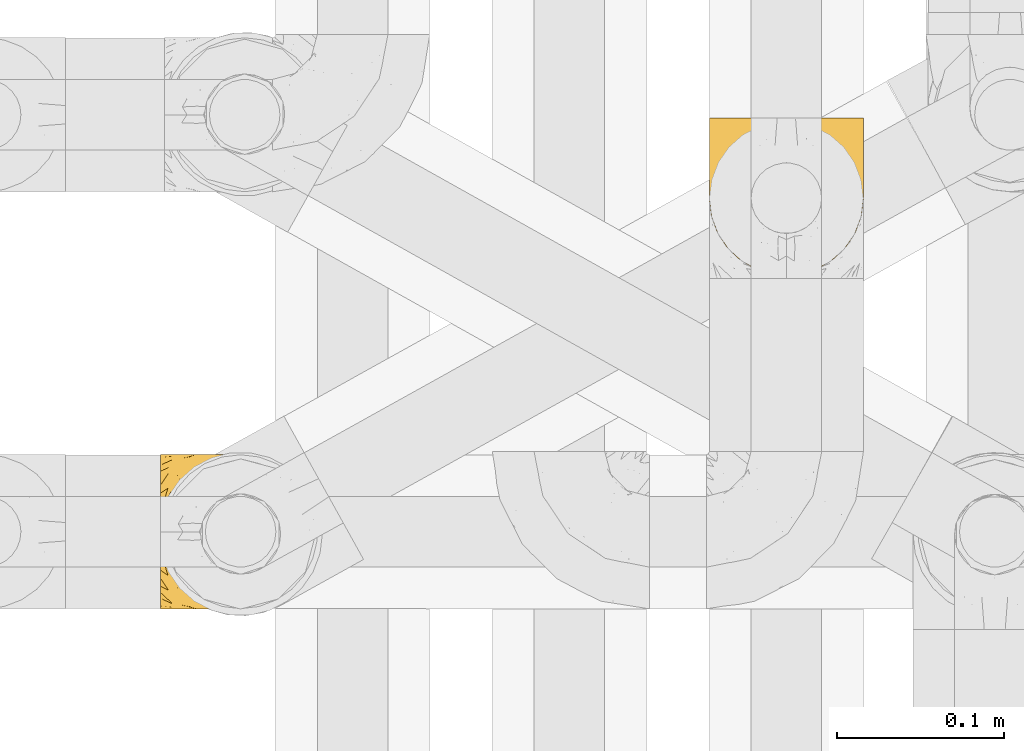
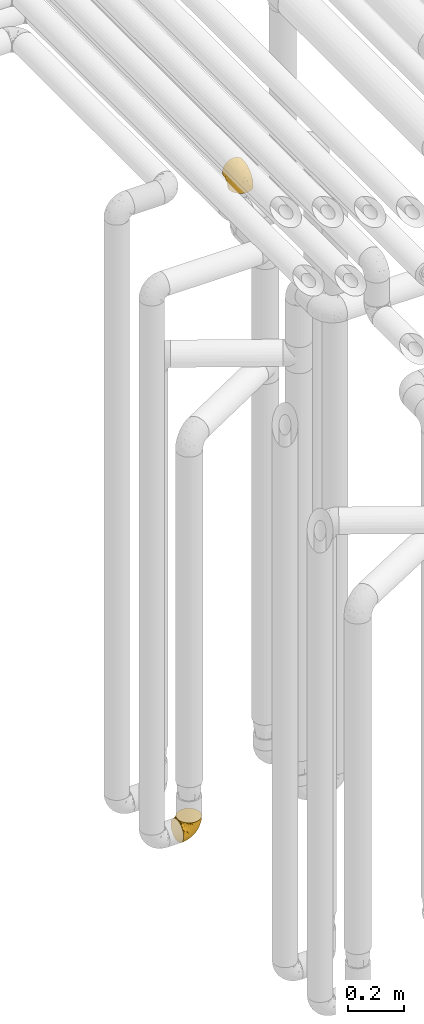
# One storey, part 171 of 827: 2 coverings.
"""IFC2X3 building model written with IfcOpenShell, lengths in millimetres."""

from ifc_helpers import new_model, entity, si_unit, converted_unit, derived_unit, direction, frame, origin, place, context, subcontext, project, spatial, faceted_brep, element, save


model = new_model("IFC2X3")

# Units and contexts
model_context = context("Model", 3, precision=0.01, world=origin(), true_north=direction((6.12303176911189e-17, 1.0)))
body_context = subcontext(model_context, "Body", "Model", "MODEL_VIEW")
ifc_project = project(units=[si_unit("LENGTHUNIT", "METRE", prefix="MILLI"), si_unit("AREAUNIT", "SQUARE_METRE"), si_unit("VOLUMEUNIT", "CUBIC_METRE"), converted_unit("PLANEANGLEUNIT", "DEGREE", entity("IfcRatioMeasure", 0.0174532925199433), si_unit("PLANEANGLEUNIT", "RADIAN"), dimensions=[0, 0, 0, 0, 0, 0, 0]), si_unit("MASSUNIT", "GRAM", prefix="KILO"), derived_unit("MASSDENSITYUNIT", [(si_unit("MASSUNIT", "GRAM", prefix="KILO"), 1), (si_unit("LENGTHUNIT", "METRE"), -3)]), derived_unit("MOMENTOFINERTIAUNIT", [(si_unit("LENGTHUNIT", "METRE"), 4)]), si_unit("TIMEUNIT", "SECOND"), si_unit("FREQUENCYUNIT", "HERTZ"), si_unit("THERMODYNAMICTEMPERATUREUNIT", "DEGREE_CELSIUS"), derived_unit("THERMALTRANSMITTANCEUNIT", [(si_unit("MASSUNIT", "GRAM", prefix="KILO"), 1), (si_unit("THERMODYNAMICTEMPERATUREUNIT", "KELVIN"), -1), (si_unit("TIMEUNIT", "SECOND"), -3)]), derived_unit("VOLUMETRICFLOWRATEUNIT", [(si_unit("LENGTHUNIT", "METRE"), 3), (si_unit("TIMEUNIT", "SECOND"), -1)]), derived_unit("MASSFLOWRATEUNIT", [(si_unit("MASSUNIT", "GRAM", prefix="KILO"), 1), (si_unit("TIMEUNIT", "SECOND"), -1)]), derived_unit("ROTATIONALFREQUENCYUNIT", [(si_unit("TIMEUNIT", "SECOND"), -1)]), si_unit("ELECTRICCURRENTUNIT", "AMPERE"), si_unit("ELECTRICVOLTAGEUNIT", "VOLT"), si_unit("POWERUNIT", "WATT"), si_unit("FORCEUNIT", "NEWTON", prefix="KILO"), si_unit("ILLUMINANCEUNIT", "LUX"), si_unit("LUMINOUSFLUXUNIT", "LUMEN"), si_unit("LUMINOUSINTENSITYUNIT", "CANDELA"), derived_unit("USERDEFINED", [(si_unit("MASSUNIT", "GRAM", prefix="KILO"), -1), (si_unit("LENGTHUNIT", "METRE"), -2), (si_unit("TIMEUNIT", "SECOND"), 3), (si_unit("LUMINOUSFLUXUNIT", "LUMEN"), 1)]), derived_unit("LINEARVELOCITYUNIT", [(si_unit("LENGTHUNIT", "METRE"), 1), (si_unit("TIMEUNIT", "SECOND"), -1)]), si_unit("PRESSUREUNIT", "PASCAL"), derived_unit("USERDEFINED", [(si_unit("LENGTHUNIT", "METRE"), -2), (si_unit("MASSUNIT", "GRAM", prefix="KILO"), 1), (si_unit("TIMEUNIT", "SECOND"), -2)]), derived_unit("LINEARFORCEUNIT", [(si_unit("MASSUNIT", "GRAM", prefix="KILO"), 1), (si_unit("LENGTHUNIT", "METRE"), 1), (si_unit("TIMEUNIT", "SECOND"), -2), (si_unit("LENGTHUNIT", "METRE"), -1)]), derived_unit("PLANARFORCEUNIT", [(si_unit("MASSUNIT", "GRAM", prefix="KILO"), 1), (si_unit("LENGTHUNIT", "METRE"), 1), (si_unit("TIMEUNIT", "SECOND"), -2), (si_unit("LENGTHUNIT", "METRE"), -2)])], contexts=[model_context])

# Site, building, storey
site_placement = place(None, origin())
site = spatial("IfcSite", under=ifc_project, at=site_placement, CompositionType="ELEMENT")
building_placement = place(site_placement, origin())
building = spatial("IfcBuilding", under=site, at=building_placement, CompositionType="ELEMENT")
storey_placement = place(building_placement, frame((0.0, 0.0, 28200.0)))
storey = spatial("IfcBuildingStorey", under=building, at=storey_placement, Name="08", CompositionType="ELEMENT", Elevation=28200.0)

# Coverings
covering_1_placement = place(storey_placement, frame((35223.31, 12708.41, 352.2)))
element("IfcCovering", 1, at=covering_1_placement, inside=storey, Name=":ADSK_", ObjectType=":ADSK_", PredefinedType="INSULATION", context=body_context, shape_type="Brep", body=[
    faceted_brep([(78.41, 11.68, 95.8), (85.72, 19.0, 95.8), (91.22, 27.76, 95.8), (94.64, 37.52, 95.8), (95.8, 47.8, 95.8), (94.64, 58.08, 95.8), (91.22, 67.85, 95.8), (85.71, 76.61, 95.8), (78.39, 83.92, 95.8), (69.63, 89.42, 95.8), (59.87, 92.84, 95.8), (49.6, 94.0, 95.8), (45.45, 93.53, 95.8), (42.38, 93.18, 95.8), (39.31, 92.84, 95.8), (34.43, 91.13, 95.8), (29.54, 89.42, 95.8), (25.16, 86.66, 95.8), (20.78, 83.91, 95.8), (17.13, 80.25, 95.8), (13.47, 76.59, 95.8), (7.97, 67.83, 95.8), (6.26, 62.95, 95.8), (4.55, 58.07, 95.8), (3.4, 47.8, 95.8), (4.55, 37.51, 95.8), (6.26, 32.63, 95.8), (7.97, 27.74, 95.8), (13.48, 18.98, 95.8), (17.14, 15.33, 95.8), (20.8, 11.67, 95.8), (25.18, 8.92, 95.8), (29.56, 6.17, 95.8), (34.44, 4.46, 95.8), (39.32, 2.75, 95.8), (42.39, 2.41, 95.8), (45.45, 2.06, 95.8), (49.6, 1.6, 95.8), (59.88, 2.75, 95.8), (69.65, 6.17, 95.8), (1.6, 47.8, 94.0), (1.6, 59.75, 92.42), (1.6, 70.9, 87.81), (1.6, 75.68, 84.13), (1.6, 80.46, 80.46), (1.6, 84.13, 75.68), (1.6, 87.81, 70.9), (1.6, 90.11, 65.32), (1.6, 92.42, 59.75), (1.6, 92.9, 56.14), (1.6, 93.17, 54.06), (1.6, 93.45, 51.97), (1.6, 94.0, 47.8), (1.6, 92.42, 35.84), (1.6, 87.81, 24.7), (1.6, 80.46, 15.13), (1.6, 70.9, 7.78), (1.6, 59.75, 3.17), (1.6, 47.8, 1.6), (1.6, 35.84, 3.17), (1.6, 24.7, 7.78), (1.6, 15.13, 15.13), (1.6, 7.78, 24.7), (1.6, 3.17, 35.84), (1.6, 1.6, 47.8), (1.6, 2.14, 51.97), (1.6, 2.69, 56.14), (1.6, 3.17, 59.75), (1.6, 5.48, 65.32), (1.6, 7.78, 70.9), (1.6, 11.46, 75.68), (1.6, 15.13, 80.46), (1.6, 19.91, 84.13), (1.6, 24.7, 87.81), (1.6, 35.84, 92.42), (36.81, 23.61, 15.84), (23.28, 31.99, 6.99), (45.8, 35.87, 14.39), (30.7, 47.8, 6.21), (21.2, 40.43, 4.26), (12.96, 47.8, 3.39), (66.19, 31.83, 31.2), (54.51, 23.37, 26.47), (17.98, 21.41, 11.44), (36.69, 3.07, 47.66), (35.54, 1.6, 61.85), (31.64, 1.6, 59.25), (27.75, 1.6, 56.65), (23.86, 1.6, 54.05), (19.96, 1.6, 51.45), (22.8, 13.45, 19.8), (42.67, 15.25, 26.22), (33.21, 8.07, 31.58), (59.45, 16.0, 38.36), (71.5, 17.34, 51.54), (62.66, 10.58, 51.6), (54.5, 5.34, 55.97), (47.57, 2.39, 62.88), (48.81, 8.36, 41.35), (74.98, 10.04, 82.24), (18.7, 2.59, 40.88), (15.75, 6.28, 29.0), (91.17, 34.28, 74.06), (85.28, 38.73, 54.53), (82.58, 27.25, 57.98), (75.78, 29.88, 43.81), (74.98, 38.6, 38.22), (67.27, 23.44, 38.33), (87.38, 25.25, 74.76), (82.04, 17.23, 76.85), (94.0, 47.8, 84.43), (77.8, 47.8, 40.43), (67.38, 47.8, 30.01), (56.2, 2.53, 78.67), (48.85, 1.6, 92.06), (48.11, 1.6, 88.32), (47.57, 1.6, 85.6), (47.03, 1.6, 82.88), (46.48, 1.6, 80.15), (45.94, 1.6, 77.43), (65.78, 5.71, 76.36), (17.24, 1.6, 50.91), (14.51, 1.6, 50.37), (11.79, 1.6, 49.82), (9.07, 1.6, 49.28), (7.2, 1.6, 48.91), (5.33, 1.6, 48.54), (91.18, 47.8, 66.69), (43.34, 1.6, 73.53), (40.74, 1.6, 69.64), (38.14, 1.6, 65.75), (72.73, 11.89, 66.13), (56.96, 47.8, 19.59), (62.23, 39.69, 24.64), (84.49, 47.8, 53.56), (43.83, 47.8, 12.9), (12.05, 13.84, 82.81), (18.95, 9.16, 81.22), (13.02, 15.79, 86.57), (8.34, 25.75, 92.75), (14.63, 16.09, 89.68), (11.09, 7.51, 72.26), (13.66, 3.99, 64.73), (20.08, 2.66, 62.45), (9.61, 3.16, 60.63), (9.48, 2.35, 56.91), (16.1, 2.23, 58.14), (3.42, 38.35, 93.7), (26.63, 6.18, 83.4), (33.72, 2.7, 75.54), (34.77, 2.93, 79.46), (6.75, 16.01, 82.28), (13.31, 9.08, 76.25), (21.11, 9.3, 84.69), (19.94, 11.68, 90.18), (8.67, 4.65, 65.12), (26.11, 3.65, 71.71), (29.3, 3.61, 75.21), (6.32, 12.8, 78.6), (39.92, 2.43, 87.27), (27.05, 6.83, 87.92), (6.04, 21.65, 86.94), (34.4, 3.7, 86.1), (2.87, 47.8, 94.52), (20.92, 3.37, 66.23), (27.43, 7.03, 91.08), (7.54, 7.87, 71.77), (18.45, 7.26, 76.21), (23.88, 3.41, 68.59), (7.77, 23.81, 89.94), (13.3, 86.5, 76.25), (11.09, 88.08, 72.26), (6.33, 82.79, 78.6), (9.07, 94.0, 49.28), (5.33, 94.0, 48.54), (14.51, 94.0, 50.37), (11.79, 94.0, 49.82), (3.42, 57.24, 93.7), (7.76, 71.76, 89.95), (47.03, 94.0, 82.88), (47.57, 94.0, 85.6), (48.85, 94.0, 92.06), (48.11, 94.0, 88.32), (14.62, 79.49, 89.68), (27.03, 88.75, 87.92), (20.08, 92.93, 62.45), (20.92, 92.22, 66.24), (27.75, 94.0, 56.65), (31.64, 94.0, 59.25), (9.61, 92.43, 60.63), (9.48, 93.24, 56.91), (8.33, 69.82, 92.76), (6.74, 79.57, 82.28), (12.04, 81.74, 82.81), (23.86, 94.0, 54.05), (19.96, 94.0, 51.45), (16.1, 93.36, 58.14), (19.93, 83.9, 90.18), (21.1, 86.28, 84.7), (39.92, 93.16, 87.25), (33.68, 92.88, 75.58), (29.28, 91.98, 75.2), (26.62, 89.41, 83.39), (26.08, 91.93, 71.7), (18.93, 86.42, 81.22), (27.87, 88.82, 90.73), (34.75, 92.66, 79.47), (6.04, 73.93, 86.94), (38.14, 94.0, 65.75), (12.79, 79.5, 86.75), (34.41, 91.89, 86.08), (45.94, 94.0, 77.43), (43.34, 94.0, 73.53), (40.74, 94.0, 69.64), (13.66, 91.6, 64.73), (17.24, 94.0, 50.91), (8.67, 90.94, 65.12), (35.54, 94.0, 61.85), (23.83, 92.16, 68.62), (18.43, 88.32, 76.22), (6.03, 86.13, 74.03), (46.48, 94.0, 80.15), (34.52, 93.2, 49.81), (21.2, 55.16, 4.26), (23.82, 82.02, 19.95), (41.32, 84.29, 30.61), (47.62, 76.94, 25.71), (52.66, 68.33, 22.43), (36.81, 71.98, 15.85), (49.75, 92.52, 60.69), (19.07, 92.9, 40.49), (45.8, 59.72, 14.39), (23.28, 63.6, 6.99), (21.35, 88.89, 29.56), (17.98, 74.18, 11.45), (82.57, 68.35, 57.98), (91.17, 61.33, 74.06), (85.27, 56.86, 54.52), (73.89, 68.62, 43.47), (66.19, 63.76, 31.2), (62.43, 72.19, 33.27), (63.53, 88.69, 64.26), (58.45, 92.19, 74.29), (67.16, 89.75, 80.41), (62.22, 55.9, 24.64), (81.54, 77.99, 73.62), (74.8, 85.21, 78.98), (75.83, 74.99, 53.69), (41.45, 90.23, 42.86), (76.72, 59.86, 41.67), (88.2, 70.75, 79.66), (71.6, 81.72, 58.41), (56.23, 86.53, 47.11), (59.44, 79.6, 38.37)], [[[0, 1, 2, 3, 4, 5, 6, 7, 8, 9, 10, 11, 12, 13, 14, 15, 16, 17, 18, 19, 20, 21, 22, 23, 24, 25, 26, 27, 28, 29, 30, 31, 32, 33, 34, 35, 36, 37, 38, 39]], [[40, 41, 42, 43, 44, 45, 46, 47, 48, 49, 50, 51, 52, 53, 54, 55, 56, 57, 58, 59, 60, 61, 62, 63, 64, 65, 66, 67, 68, 69, 70, 71, 72, 73, 74]], [[75, 76, 77]], [[78, 79, 80]], [[77, 81, 82]], [[76, 75, 83]], [[84, 85, 86, 87, 88, 89]], [[90, 91, 92]], [[76, 60, 59]], [[93, 94, 95]], [[90, 62, 61]], [[83, 61, 60]], [[96, 97, 84]], [[98, 93, 95]], [[0, 39, 99]], [[100, 84, 89]], [[62, 101, 63]], [[2, 102, 3]], [[92, 84, 100]], [[103, 102, 104]], [[103, 105, 106]], [[93, 107, 94]], [[1, 108, 2]], [[92, 101, 90]], [[108, 1, 109]], [[102, 110, 3]], [[93, 82, 107]], [[102, 108, 104]], [[111, 106, 112]], [[109, 0, 99]], [[113, 37, 114, 115, 116, 117, 118, 119]], [[120, 38, 113]], [[100, 89, 121, 122, 123, 124, 125, 126, 64]], [[127, 102, 103]], [[97, 119, 128, 129, 130, 85]], [[99, 120, 131]], [[132, 133, 77]], [[59, 80, 79]], [[1, 0, 109]], [[98, 84, 92]], [[94, 109, 131]], [[120, 39, 38]], [[93, 91, 82]], [[104, 94, 105]], [[97, 113, 119]], [[95, 120, 96]], [[83, 90, 61]], [[91, 93, 98]], [[64, 63, 100]], [[100, 63, 101]], [[77, 76, 79]], [[133, 106, 81]], [[84, 97, 85]], [[113, 96, 120]], [[113, 97, 96]], [[37, 113, 38]], [[110, 102, 127]], [[110, 4, 3]], [[103, 111, 134, 127]], [[90, 75, 91]], [[82, 81, 107]], [[91, 75, 82]], [[77, 82, 75]], [[76, 83, 60]], [[90, 83, 75]], [[105, 107, 81]], [[94, 131, 95]], [[105, 94, 107]], [[109, 94, 104]], [[120, 95, 131]], [[98, 95, 96]], [[84, 98, 96]], [[98, 92, 91]], [[106, 105, 81]], [[103, 104, 105]], [[112, 106, 133]], [[103, 106, 111]], [[112, 133, 132]], [[81, 77, 133]], [[77, 78, 135, 132]], [[120, 99, 39]], [[109, 99, 131]], [[59, 58, 80]], [[59, 79, 76]], [[90, 101, 62]], [[100, 101, 92]], [[2, 108, 102]], [[109, 104, 108]], [[78, 77, 79]], [[136, 137, 138]], [[27, 139, 140]], [[141, 142, 143]], [[144, 145, 121]], [[146, 89, 88]], [[147, 139, 25]], [[148, 149, 150]], [[136, 151, 152]], [[147, 40, 74]], [[24, 147, 25]], [[140, 153, 154]], [[33, 116, 34]], [[73, 72, 151]], [[114, 37, 36, 35, 34, 116, 115]], [[146, 155, 144]], [[156, 85, 130]], [[157, 149, 148]], [[151, 158, 152]], [[117, 33, 159]], [[29, 154, 160]], [[161, 74, 73]], [[162, 128, 119]], [[66, 65, 64, 126, 125, 124, 123, 122, 67]], [[163, 147, 24]], [[27, 140, 28]], [[149, 129, 150]], [[139, 27, 26, 25]], [[68, 144, 69]], [[129, 128, 150]], [[164, 87, 86]], [[130, 129, 149]], [[122, 145, 67]], [[154, 153, 148]], [[162, 119, 159]], [[165, 30, 160]], [[150, 160, 148]], [[128, 162, 150]], [[30, 165, 31]], [[145, 144, 68]], [[89, 146, 144]], [[87, 164, 143]], [[166, 155, 142]], [[88, 87, 143]], [[162, 160, 150]], [[160, 30, 29]], [[154, 29, 28]], [[140, 154, 28]], [[160, 154, 148]], [[140, 137, 153]], [[157, 148, 153]], [[156, 130, 157]], [[153, 137, 157]], [[157, 137, 156]], [[167, 137, 136]], [[168, 85, 156]], [[152, 168, 167]], [[167, 168, 156]], [[164, 152, 141]], [[71, 158, 72]], [[152, 167, 136]], [[88, 142, 146]], [[144, 155, 69]], [[146, 142, 155]], [[70, 166, 71]], [[142, 141, 166]], [[70, 69, 155]], [[141, 158, 71]], [[161, 73, 151]], [[138, 137, 140]], [[161, 136, 169]], [[136, 161, 151]], [[74, 161, 169]], [[152, 158, 141]], [[151, 72, 158]], [[168, 152, 164]], [[137, 167, 156]], [[164, 86, 168]], [[85, 168, 86]], [[116, 33, 117]], [[130, 149, 157]], [[67, 145, 68]], [[121, 89, 144]], [[145, 122, 121]], [[40, 147, 163]], [[169, 147, 74]], [[159, 33, 32]], [[162, 159, 32]], [[159, 119, 118, 117]], [[139, 147, 169]], [[139, 169, 138]], [[162, 32, 31]], [[141, 143, 164]], [[88, 143, 142]], [[71, 166, 141]], [[155, 166, 70]], [[139, 138, 140]], [[169, 136, 138]], [[160, 162, 165]], [[162, 31, 165]], [[170, 171, 172]], [[173, 174, 52, 51, 50, 49, 48, 175, 176]], [[177, 178, 41]], [[179, 15, 180]], [[12, 11, 181, 182, 180, 14, 13]], [[183, 21, 20]], [[19, 18, 184]], [[185, 186, 187]], [[186, 188, 187]], [[43, 172, 44]], [[189, 190, 47]], [[23, 22, 21, 191]], [[170, 192, 193]], [[40, 163, 177]], [[194, 195, 196]], [[24, 23, 177]], [[197, 198, 183]], [[199, 15, 179]], [[47, 46, 189]], [[200, 201, 202]], [[201, 203, 204]], [[205, 206, 184]], [[207, 41, 178]], [[16, 15, 199]], [[14, 180, 15]], [[202, 201, 198]], [[208, 201, 200]], [[163, 24, 177]], [[48, 47, 190]], [[196, 195, 189]], [[197, 184, 202]], [[204, 193, 209]], [[210, 211, 212]], [[206, 212, 213]], [[205, 17, 210]], [[184, 206, 202]], [[210, 212, 206]], [[185, 194, 214]], [[189, 215, 190]], [[216, 45, 214]], [[186, 171, 170]], [[189, 216, 196]], [[197, 20, 19]], [[194, 185, 187]], [[197, 183, 20]], [[184, 197, 19]], [[197, 202, 198]], [[206, 200, 202]], [[204, 183, 198]], [[201, 208, 203]], [[203, 208, 217]], [[204, 198, 201]], [[217, 188, 218]], [[193, 219, 170]], [[171, 186, 185]], [[170, 218, 186]], [[170, 219, 218]], [[42, 207, 192]], [[171, 220, 172]], [[216, 189, 46]], [[214, 194, 196]], [[44, 220, 45]], [[214, 196, 216]], [[216, 46, 45]], [[214, 45, 220]], [[192, 43, 42]], [[204, 203, 219]], [[207, 193, 192]], [[209, 193, 178]], [[41, 207, 42]], [[193, 207, 178]], [[43, 192, 172]], [[170, 172, 192]], [[204, 219, 193]], [[219, 203, 218]], [[217, 218, 203]], [[188, 186, 218]], [[206, 213, 200]], [[208, 200, 213]], [[199, 210, 16]], [[215, 189, 195]], [[215, 175, 190]], [[175, 48, 190]], [[199, 179, 221, 211]], [[210, 199, 211]], [[23, 191, 177]], [[40, 177, 41]], [[178, 177, 191]], [[21, 183, 191]], [[209, 191, 183]], [[205, 18, 17]], [[17, 16, 210]], [[171, 185, 214]], [[172, 220, 44]], [[214, 220, 171]], [[191, 209, 178]], [[204, 209, 183]], [[206, 205, 210]], [[18, 205, 184]], [[222, 195, 194, 187, 188, 217]], [[57, 223, 80]], [[224, 225, 226]], [[226, 227, 228]], [[229, 217, 208, 213, 212, 211]], [[230, 52, 174, 173, 176, 175, 215, 195]], [[231, 232, 228]], [[231, 78, 223]], [[223, 57, 232]], [[224, 233, 225]], [[233, 54, 53]], [[234, 232, 56]], [[56, 55, 234]], [[234, 224, 228]], [[235, 236, 237]], [[224, 55, 54]], [[238, 239, 240]], [[52, 230, 53]], [[241, 242, 243]], [[227, 244, 231]], [[11, 10, 242]], [[236, 6, 5]], [[7, 245, 8]], [[8, 246, 9]], [[238, 247, 235]], [[222, 229, 248]], [[242, 211, 221, 179, 180, 182, 181, 11]], [[233, 53, 230]], [[111, 112, 249]], [[250, 6, 236]], [[246, 251, 241]], [[6, 250, 7]], [[127, 236, 110]], [[248, 229, 252]], [[246, 8, 245]], [[235, 245, 250]], [[236, 5, 110]], [[235, 249, 238]], [[237, 236, 127]], [[243, 9, 246]], [[252, 229, 241]], [[56, 232, 57]], [[222, 230, 195]], [[225, 248, 252]], [[248, 233, 230]], [[54, 233, 224]], [[231, 228, 227]], [[244, 132, 231]], [[248, 225, 233]], [[226, 225, 253]], [[235, 250, 236]], [[245, 7, 250]], [[251, 246, 245]], [[243, 246, 241]], [[247, 245, 235]], [[252, 251, 253]], [[229, 222, 217]], [[230, 222, 248]], [[5, 4, 110]], [[237, 127, 134, 111]], [[238, 249, 239]], [[224, 234, 55]], [[232, 234, 228]], [[242, 241, 229]], [[10, 9, 243]], [[211, 242, 229]], [[10, 243, 242]], [[80, 223, 78]], [[80, 58, 57]], [[231, 223, 232]], [[227, 240, 239]], [[224, 226, 228]], [[240, 226, 253]], [[227, 239, 244]], [[226, 240, 227]], [[251, 247, 253]], [[240, 253, 247]], [[249, 235, 237]], [[237, 111, 249]], [[112, 132, 244]], [[112, 244, 249]], [[78, 231, 132, 135]], [[249, 244, 239]], [[247, 238, 240]], [[245, 247, 251]], [[251, 252, 241]], [[225, 252, 253]]]),
])
covering_2_placement = place(storey_placement, frame((35552.3, 12908.38, 2950.4)))
element("IfcCovering", 2, at=covering_2_placement, inside=storey, Name=":ADSK_", ObjectType=":ADSK_", PredefinedType="INSULATION", context=body_context, shape_type="Brep", body=[
    faceted_brep([(83.91, 18.98, 1.6), (76.59, 11.67, 1.6), (67.83, 6.17, 1.6), (58.07, 2.75, 1.6), (47.8, 1.6, 1.6), (37.51, 2.75, 1.6), (27.74, 6.17, 1.6), (18.98, 11.68, 1.6), (11.67, 19.0, 1.6), (6.17, 27.76, 1.6), (2.75, 37.52, 1.6), (1.6, 47.8, 1.6), (2.06, 51.94, 1.6), (2.41, 55.01, 1.6), (2.75, 58.08, 1.6), (4.46, 62.96, 1.6), (6.17, 67.85, 1.6), (8.93, 72.23, 1.6), (11.68, 76.61, 1.6), (15.34, 80.26, 1.6), (19.0, 83.92, 1.6), (27.76, 89.42, 1.6), (32.64, 91.13, 1.6), (37.52, 92.84, 1.6), (47.8, 94.0, 1.6), (58.08, 92.84, 1.6), (62.96, 91.13, 1.6), (67.85, 89.42, 1.6), (76.61, 83.91, 1.6), (80.26, 80.25, 1.6), (83.92, 76.59, 1.6), (86.67, 72.21, 1.6), (89.42, 67.83, 1.6), (91.13, 62.95, 1.6), (92.84, 58.07, 1.6), (93.18, 55.0, 1.6), (93.53, 51.94, 1.6), (94.0, 47.8, 1.6), (92.84, 37.51, 1.6), (89.42, 27.74, 1.6), (47.8, 95.8, 3.4), (35.84, 95.8, 4.97), (24.7, 95.8, 9.58), (19.91, 95.8, 13.26), (15.13, 95.8, 16.93), (11.46, 95.8, 21.71), (7.78, 95.8, 26.5), (5.48, 95.8, 32.07), (3.17, 95.8, 37.64), (2.69, 95.8, 41.25), (2.42, 95.8, 43.34), (2.14, 95.8, 45.42), (1.6, 95.8, 49.6), (3.17, 95.8, 61.55), (7.78, 95.8, 72.7), (15.13, 95.8, 82.26), (24.7, 95.8, 89.61), (35.84, 95.8, 94.22), (47.8, 95.8, 95.8), (59.75, 95.8, 94.22), (70.9, 95.8, 89.61), (80.46, 95.8, 82.26), (87.81, 95.8, 72.7), (92.42, 95.8, 61.55), (94.0, 95.8, 49.6), (93.45, 95.8, 45.42), (92.9, 95.8, 41.25), (92.42, 95.8, 37.64), (90.11, 95.8, 32.07), (87.81, 95.8, 26.5), (84.13, 95.8, 21.71), (80.46, 95.8, 16.93), (75.68, 95.8, 13.26), (70.9, 95.8, 9.58), (59.75, 95.8, 4.97), (71.98, 60.58, 81.55), (63.6, 74.11, 90.4), (59.72, 51.59, 83.0), (47.8, 66.69, 91.18), (55.16, 76.19, 93.13), (47.8, 84.43, 94.0), (63.76, 31.2, 66.19), (72.22, 42.88, 70.92), (74.18, 79.41, 85.95), (92.52, 60.7, 49.74), (94.0, 61.85, 35.54), (94.0, 65.75, 38.14), (94.0, 69.64, 40.74), (94.0, 73.53, 43.34), (94.0, 77.43, 45.94), (82.14, 74.59, 77.59), (80.34, 54.72, 71.17), (87.52, 64.18, 65.81), (79.59, 37.94, 59.03), (78.25, 25.89, 45.85), (85.01, 34.73, 45.79), (90.25, 42.89, 41.42), (93.2, 49.83, 34.51), (87.23, 48.58, 56.04), (85.55, 22.41, 15.15), (93.0, 78.69, 56.51), (89.31, 81.64, 68.39), (61.31, 6.22, 23.33), (56.86, 12.11, 42.86), (68.34, 14.81, 39.42), (65.71, 21.61, 53.58), (56.99, 22.41, 59.17), (72.15, 30.12, 59.06), (70.34, 10.01, 22.63), (78.36, 15.36, 20.55), (47.8, 3.39, 12.96), (47.8, 19.59, 56.96), (47.8, 30.01, 67.38), (93.06, 41.19, 18.72), (94.0, 48.54, 5.33), (94.0, 49.28, 9.07), (94.0, 49.82, 11.79), (94.0, 50.37, 14.51), (94.0, 50.91, 17.24), (94.0, 51.45, 19.96), (89.88, 31.61, 21.03), (94.0, 80.15, 46.48), (94.0, 82.88, 47.03), (94.0, 85.6, 47.57), (94.0, 88.32, 48.11), (94.0, 90.19, 48.48), (94.0, 92.06, 48.85), (47.8, 6.21, 30.7), (94.0, 54.05, 23.86), (94.0, 56.65, 27.75), (94.0, 59.25, 31.64), (83.7, 24.66, 31.26), (47.8, 40.43, 77.8), (55.9, 35.17, 72.75), (47.8, 12.9, 43.83), (47.8, 53.56, 84.49), (81.75, 85.34, 14.58), (86.43, 78.44, 16.17), (79.8, 84.37, 10.82), (69.84, 89.05, 4.64), (79.5, 82.76, 7.71), (88.08, 86.31, 25.13), (91.6, 83.73, 32.66), (92.93, 77.31, 34.94), (92.43, 87.78, 36.76), (93.24, 87.91, 40.48), (93.36, 81.29, 39.25), (57.25, 93.97, 3.69), (89.41, 70.76, 13.99), (92.89, 63.67, 21.85), (92.66, 62.62, 17.93), (79.58, 90.64, 15.11), (86.51, 84.08, 21.14), (86.29, 76.28, 12.7), (83.91, 77.45, 7.21), (90.94, 88.72, 32.27), (91.94, 71.28, 25.68), (91.98, 68.09, 22.18), (82.79, 91.07, 18.79), (93.16, 57.47, 10.12), (88.76, 70.34, 9.47), (73.94, 91.35, 10.45), (91.89, 62.99, 11.29), (47.8, 94.52, 2.87), (92.22, 76.47, 31.16), (88.56, 69.96, 6.31), (87.72, 89.86, 25.62), (88.33, 78.94, 21.18), (92.18, 73.51, 28.81), (71.78, 89.62, 7.45), (9.09, 84.09, 21.14), (7.51, 86.3, 25.13), (12.8, 91.06, 18.79), (1.6, 88.32, 48.11), (1.6, 92.06, 48.85), (1.6, 82.88, 47.03), (1.6, 85.6, 47.57), (38.35, 93.97, 3.69), (23.84, 89.63, 7.44), (1.6, 50.37, 14.51), (1.6, 49.82, 11.79), (1.6, 48.54, 5.33), (1.6, 49.28, 9.07), (16.1, 82.77, 7.71), (6.84, 70.36, 9.47), (2.66, 77.31, 34.94), (3.37, 76.47, 31.16), (1.6, 69.64, 40.74), (1.6, 65.75, 38.14), (3.16, 87.78, 36.76), (2.35, 87.91, 40.48), (25.77, 89.06, 4.63), (16.02, 90.65, 15.11), (13.85, 85.35, 14.58), (1.6, 73.53, 43.34), (1.6, 77.43, 45.94), (2.23, 81.29, 39.25), (11.69, 77.46, 7.21), (9.31, 76.29, 12.69), (2.43, 57.47, 10.14), (2.71, 63.71, 21.81), (3.61, 68.11, 22.19), (6.18, 70.77, 14.0), (3.66, 71.31, 25.69), (9.17, 78.46, 16.17), (6.77, 69.52, 6.66), (2.93, 62.64, 17.92), (21.66, 91.35, 10.45), (1.6, 59.25, 31.64), (16.09, 84.6, 10.64), (3.7, 62.98, 11.31), (1.6, 51.45, 19.96), (1.6, 54.05, 23.86), (1.6, 56.65, 27.75), (3.99, 83.73, 32.66), (1.6, 80.15, 46.48), (4.65, 88.72, 32.27), (1.6, 61.85, 35.54), (3.43, 73.56, 28.77), (7.27, 78.96, 21.17), (9.46, 91.36, 23.36), (1.6, 50.91, 17.24), (2.4, 62.87, 47.58), (40.43, 76.19, 93.13), (13.57, 73.57, 77.44), (11.3, 56.07, 66.78), (18.65, 49.77, 71.68), (27.26, 44.73, 74.96), (23.61, 60.58, 81.55), (3.07, 47.64, 36.7), (2.69, 78.32, 56.9), (35.87, 51.59, 83.0), (31.99, 74.11, 90.4), (6.71, 76.04, 67.83), (21.41, 79.41, 85.95), (27.24, 14.82, 39.41), (34.26, 6.22, 23.33), (38.73, 12.12, 42.87), (26.97, 23.51, 53.92), (31.83, 31.2, 66.19), (23.4, 34.96, 64.12), (6.91, 33.86, 33.13), (3.4, 38.94, 23.1), (5.84, 30.23, 16.98), (35.73, 20.67, 55.72), (39.69, 35.17, 72.75), (17.6, 15.85, 23.77), (10.38, 22.59, 18.41), (20.6, 21.56, 43.7), (5.36, 55.94, 54.53), (24.84, 9.19, 17.73), (13.87, 25.79, 38.98), (9.06, 41.16, 50.28), (15.99, 37.95, 59.02)], [[[0, 1, 2, 3, 4, 5, 6, 7, 8, 9, 10, 11, 12, 13, 14, 15, 16, 17, 18, 19, 20, 21, 22, 23, 24, 25, 26, 27, 28, 29, 30, 31, 32, 33, 34, 35, 36, 37, 38, 39]], [[40, 41, 42, 43, 44, 45, 46, 47, 48, 49, 50, 51, 52, 53, 54, 55, 56, 57, 58, 59, 60, 61, 62, 63, 64, 65, 66, 67, 68, 69, 70, 71, 72, 73, 74]], [[75, 76, 77]], [[78, 79, 80]], [[77, 81, 82]], [[76, 75, 83]], [[84, 85, 86, 87, 88, 89]], [[90, 91, 92]], [[76, 60, 59]], [[93, 94, 95]], [[90, 62, 61]], [[83, 61, 60]], [[96, 97, 84]], [[98, 93, 95]], [[0, 39, 99]], [[100, 84, 89]], [[62, 101, 63]], [[2, 102, 3]], [[92, 84, 100]], [[103, 102, 104]], [[103, 105, 106]], [[93, 107, 94]], [[1, 108, 2]], [[92, 101, 90]], [[108, 1, 109]], [[102, 110, 3]], [[93, 82, 107]], [[102, 108, 104]], [[111, 106, 112]], [[109, 0, 99]], [[113, 37, 114, 115, 116, 117, 118, 119]], [[120, 38, 113]], [[100, 89, 121, 122, 123, 124, 125, 126, 64]], [[127, 102, 103]], [[97, 119, 128, 129, 130, 85]], [[99, 120, 131]], [[132, 133, 77]], [[59, 80, 79]], [[1, 0, 109]], [[98, 84, 92]], [[94, 109, 131]], [[120, 39, 38]], [[93, 91, 82]], [[104, 94, 105]], [[97, 113, 119]], [[95, 120, 96]], [[83, 90, 61]], [[91, 93, 98]], [[64, 63, 100]], [[100, 63, 101]], [[77, 76, 79]], [[133, 106, 81]], [[84, 97, 85]], [[113, 96, 120]], [[113, 97, 96]], [[37, 113, 38]], [[110, 102, 127]], [[110, 4, 3]], [[103, 111, 134, 127]], [[90, 75, 91]], [[82, 81, 107]], [[91, 75, 82]], [[77, 82, 75]], [[76, 83, 60]], [[90, 83, 75]], [[105, 107, 81]], [[94, 131, 95]], [[105, 94, 107]], [[109, 94, 104]], [[120, 95, 131]], [[98, 95, 96]], [[84, 98, 96]], [[98, 92, 91]], [[106, 105, 81]], [[103, 104, 105]], [[112, 106, 133]], [[103, 106, 111]], [[112, 133, 132]], [[81, 77, 133]], [[77, 78, 135, 132]], [[120, 99, 39]], [[109, 99, 131]], [[59, 58, 80]], [[59, 79, 76]], [[90, 101, 62]], [[100, 101, 92]], [[2, 108, 102]], [[109, 104, 108]], [[78, 77, 79]], [[136, 137, 138]], [[27, 139, 140]], [[141, 142, 143]], [[144, 145, 121]], [[146, 89, 88]], [[147, 139, 25]], [[148, 149, 150]], [[136, 151, 152]], [[147, 40, 74]], [[24, 147, 25]], [[140, 153, 154]], [[33, 116, 34]], [[73, 72, 151]], [[114, 37, 36, 35, 34, 116, 115]], [[146, 155, 144]], [[156, 85, 130]], [[157, 149, 148]], [[151, 158, 152]], [[117, 33, 159]], [[29, 154, 160]], [[161, 74, 73]], [[162, 128, 119]], [[66, 65, 64, 126, 125, 124, 123, 122, 67]], [[163, 147, 24]], [[27, 140, 28]], [[149, 129, 150]], [[139, 27, 26, 25]], [[68, 144, 69]], [[129, 128, 150]], [[164, 87, 86]], [[130, 129, 149]], [[122, 145, 67]], [[154, 153, 148]], [[162, 119, 159]], [[165, 30, 160]], [[150, 160, 148]], [[128, 162, 150]], [[30, 165, 31]], [[145, 144, 68]], [[89, 146, 144]], [[87, 164, 143]], [[166, 155, 142]], [[88, 87, 143]], [[162, 160, 150]], [[160, 30, 29]], [[154, 29, 28]], [[140, 154, 28]], [[160, 154, 148]], [[140, 137, 153]], [[157, 148, 153]], [[156, 130, 157]], [[153, 137, 157]], [[157, 137, 156]], [[167, 137, 136]], [[168, 85, 156]], [[152, 168, 167]], [[167, 168, 156]], [[164, 152, 141]], [[71, 158, 72]], [[152, 167, 136]], [[88, 142, 146]], [[144, 155, 69]], [[146, 142, 155]], [[70, 166, 71]], [[142, 141, 166]], [[70, 69, 155]], [[141, 158, 71]], [[161, 73, 151]], [[138, 137, 140]], [[161, 136, 169]], [[136, 161, 151]], [[74, 161, 169]], [[152, 158, 141]], [[151, 72, 158]], [[168, 152, 164]], [[137, 167, 156]], [[164, 86, 168]], [[85, 168, 86]], [[116, 33, 117]], [[130, 149, 157]], [[67, 145, 68]], [[121, 89, 144]], [[145, 122, 121]], [[40, 147, 163]], [[169, 147, 74]], [[159, 33, 32]], [[162, 159, 32]], [[159, 119, 118, 117]], [[139, 147, 169]], [[139, 169, 138]], [[162, 32, 31]], [[141, 143, 164]], [[88, 143, 142]], [[71, 166, 141]], [[155, 166, 70]], [[139, 138, 140]], [[169, 136, 138]], [[160, 162, 165]], [[162, 31, 165]], [[170, 171, 172]], [[173, 174, 52, 51, 50, 49, 48, 175, 176]], [[177, 178, 41]], [[179, 15, 180]], [[12, 11, 181, 182, 180, 14, 13]], [[183, 21, 20]], [[19, 18, 184]], [[185, 186, 187]], [[186, 188, 187]], [[43, 172, 44]], [[189, 190, 47]], [[23, 22, 21, 191]], [[170, 192, 193]], [[40, 163, 177]], [[194, 195, 196]], [[24, 23, 177]], [[197, 198, 183]], [[199, 15, 179]], [[47, 46, 189]], [[200, 201, 202]], [[201, 203, 204]], [[205, 206, 184]], [[207, 41, 178]], [[16, 15, 199]], [[14, 180, 15]], [[202, 201, 198]], [[208, 201, 200]], [[163, 24, 177]], [[48, 47, 190]], [[196, 195, 189]], [[197, 184, 202]], [[204, 193, 209]], [[210, 211, 212]], [[206, 212, 213]], [[205, 17, 210]], [[184, 206, 202]], [[210, 212, 206]], [[185, 194, 214]], [[189, 215, 190]], [[216, 45, 214]], [[186, 171, 170]], [[189, 216, 196]], [[197, 20, 19]], [[194, 185, 187]], [[197, 183, 20]], [[184, 197, 19]], [[197, 202, 198]], [[206, 200, 202]], [[204, 183, 198]], [[201, 208, 203]], [[203, 208, 217]], [[204, 198, 201]], [[217, 188, 218]], [[193, 219, 170]], [[171, 186, 185]], [[170, 218, 186]], [[170, 219, 218]], [[42, 207, 192]], [[171, 220, 172]], [[216, 189, 46]], [[214, 194, 196]], [[44, 220, 45]], [[214, 196, 216]], [[216, 46, 45]], [[214, 45, 220]], [[192, 43, 42]], [[204, 203, 219]], [[207, 193, 192]], [[209, 193, 178]], [[41, 207, 42]], [[193, 207, 178]], [[43, 192, 172]], [[170, 172, 192]], [[204, 219, 193]], [[219, 203, 218]], [[217, 218, 203]], [[188, 186, 218]], [[206, 213, 200]], [[208, 200, 213]], [[199, 210, 16]], [[215, 189, 195]], [[215, 175, 190]], [[175, 48, 190]], [[199, 179, 221, 211]], [[210, 199, 211]], [[23, 191, 177]], [[40, 177, 41]], [[178, 177, 191]], [[21, 183, 191]], [[209, 191, 183]], [[205, 18, 17]], [[17, 16, 210]], [[171, 185, 214]], [[172, 220, 44]], [[214, 220, 171]], [[191, 209, 178]], [[204, 209, 183]], [[206, 205, 210]], [[18, 205, 184]], [[222, 195, 194, 187, 188, 217]], [[57, 223, 80]], [[224, 225, 226]], [[226, 227, 228]], [[229, 217, 208, 213, 212, 211]], [[230, 52, 174, 173, 176, 175, 215, 195]], [[231, 232, 228]], [[231, 78, 223]], [[223, 57, 232]], [[224, 233, 225]], [[233, 54, 53]], [[234, 232, 56]], [[56, 55, 234]], [[234, 224, 228]], [[235, 236, 237]], [[224, 55, 54]], [[238, 239, 240]], [[52, 230, 53]], [[241, 242, 243]], [[239, 244, 245]], [[11, 10, 242]], [[236, 6, 5]], [[7, 246, 8]], [[8, 247, 9]], [[238, 248, 235]], [[222, 229, 249]], [[242, 211, 221, 179, 180, 182, 181, 11]], [[233, 53, 230]], [[111, 112, 244]], [[250, 6, 236]], [[247, 251, 241]], [[6, 250, 7]], [[127, 236, 110]], [[249, 229, 252]], [[247, 8, 246]], [[235, 246, 250]], [[236, 5, 110]], [[235, 244, 238]], [[237, 236, 127]], [[243, 9, 247]], [[252, 229, 241]], [[56, 232, 57]], [[222, 230, 195]], [[225, 249, 252]], [[249, 233, 230]], [[54, 233, 224]], [[231, 228, 227]], [[245, 132, 231]], [[249, 225, 233]], [[226, 225, 253]], [[235, 250, 236]], [[246, 7, 250]], [[251, 247, 246]], [[243, 247, 241]], [[248, 246, 235]], [[252, 251, 253]], [[229, 222, 217]], [[230, 222, 249]], [[5, 4, 110]], [[237, 127, 134, 111]], [[238, 244, 239]], [[224, 234, 55]], [[232, 234, 228]], [[242, 241, 229]], [[10, 9, 243]], [[211, 242, 229]], [[10, 243, 242]], [[80, 223, 78]], [[80, 58, 57]], [[231, 223, 232]], [[227, 240, 239]], [[224, 226, 228]], [[240, 226, 253]], [[227, 239, 245]], [[226, 240, 227]], [[251, 248, 253]], [[240, 253, 248]], [[244, 235, 237]], [[237, 111, 244]], [[132, 245, 112]], [[112, 245, 244]], [[135, 78, 231, 132]], [[227, 245, 231]], [[248, 238, 240]], [[246, 248, 251]], [[251, 252, 241]], [[225, 252, 253]]]),
])

save(model, "model.ifc")
